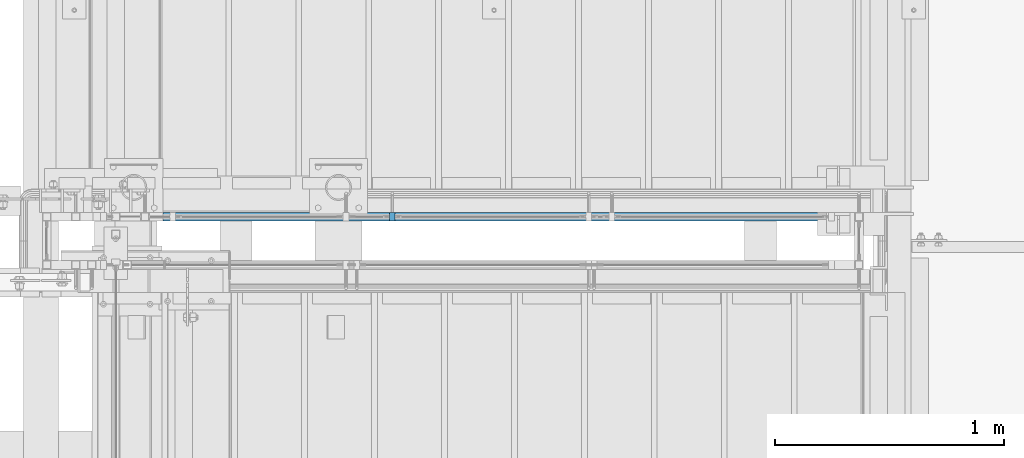
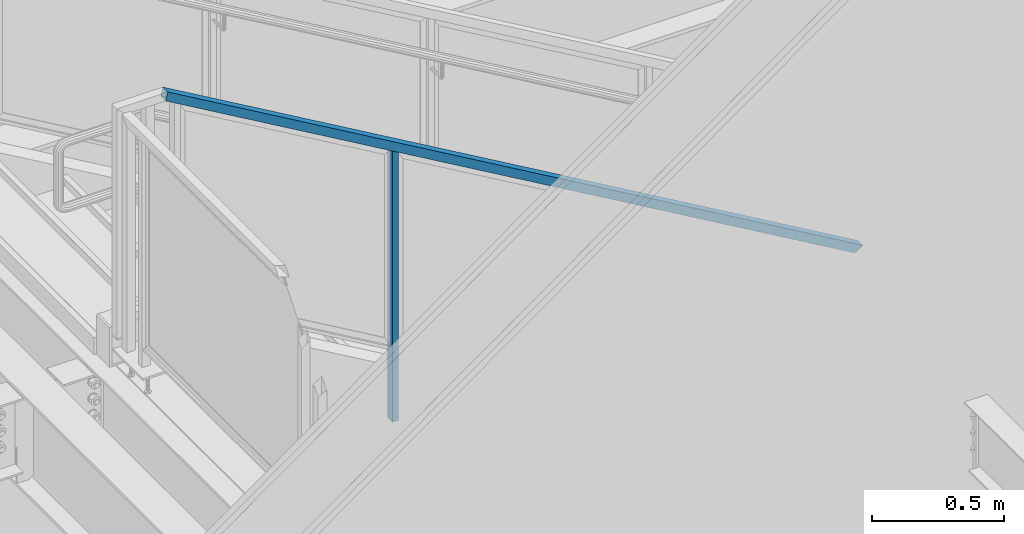
# One storey, part 794 of 1179: 2 members, 1 element without a shape of its own.
"""IFC2X3 building model written with IfcOpenShell, lengths in millimetres."""

from ifc_helpers import new_model, si_unit, frame, origin_with_axes, place, context, subcontext, project, spatial, faceted_brep, material, type_object, element, aggregate, save


model = new_model("IFC2X3")

# Units and contexts
model_context = context("Model", 3, precision=1e-05, world=origin_with_axes())
body_context = subcontext(model_context, "Body", "Model", "MODEL_VIEW")
ifc_project = project(units=[si_unit("LENGTHUNIT", "METRE", prefix="MILLI"), si_unit("AREAUNIT", "SQUARE_METRE"), si_unit("VOLUMEUNIT", "CUBIC_METRE"), si_unit("MASSUNIT", "GRAM", prefix="KILO"), si_unit("TIMEUNIT", "SECOND"), si_unit("PLANEANGLEUNIT", "RADIAN"), si_unit("SOLIDANGLEUNIT", "STERADIAN"), si_unit("THERMODYNAMICTEMPERATUREUNIT", "DEGREE_CELSIUS"), si_unit("LUMINOUSINTENSITYUNIT", "LUMEN")], contexts=[model_context])

# Site, building, storey
site_placement = place(None, origin_with_axes())
site = spatial("IfcSite", under=ifc_project, at=site_placement, CompositionType="ELEMENT")
building_placement = place(site_placement, origin_with_axes())
building = spatial("IfcBuilding", under=site, at=building_placement, Name="Undefined", CompositionType="ELEMENT")
storey_placement = place(building_placement, origin_with_axes())
storey = spatial("IfcBuildingStorey", under=building, at=storey_placement, Name="Undefined", CompositionType="ELEMENT", Elevation=0.0)

# Assembly, members
assembly_placement = place(storey_placement, origin_with_axes())
assembly = element("IfcElementAssembly", 1, at=assembly_placement, inside=storey, Name="GUARDRAIL", AssemblyPlace="NOTDEFINED", PredefinedType="RIGID_FRAME")
ifc_material_1 = material(Name="STEEL/A36")
member_type_1 = type_object("IfcMemberType", PredefinedType="NOTDEFINED")
member_1_placement = place(assembly_placement, frame((20810.0083338412, 39681.1500007796, 7355.33459241118), z_axis=(0.0, -1.0, 0.0), x_axis=(0.0, 0.0, 1.0)))
member_1 = element("IfcMember", 2, at=member_1_placement, type_object=member_type_1, material=ifc_material_1, Name="POST", context=body_context, shape_type="Brep", body=[
    faceted_brep([(0.0, 12.7000000000007, -19.0500000000029), (0.0, 12.7000000000007, 19.0500000000029), (1257.9937907086, 12.7000000000007, 19.0500000000029), (1257.9937907086, 12.7000000000007, -19.0500000000029), (0.0, -12.7000000000007, 19.0500000000029), (1243.17712405909, -12.7000000000007, 19.0500000000029), (0.0, -12.7000000000007, -19.0500000000029), (1243.17712405909, -12.7000000000007, -19.0500000000029)], [[[0, 1, 2, 3]], [[1, 4, 5, 2]], [[4, 6, 7, 5]], [[6, 0, 3, 7]], [[5, 7, 3, 2]], [[6, 4, 1, 0]]]),
])
ifc_material_2 = material()
member_type_2 = type_object("IfcMemberType", Name="HSS1-1/2X1-1/2X1/8", PredefinedType="NOTDEFINED")
member_2_placement = place(assembly_placement, frame((19805.65, 39681.150000777, 9213.8499999772), z_axis=(0.503871025088838, 0.0, 0.863778901152328), x_axis=(0.863778851027978, 0.0, -0.503871111016285)))
member_2 = element("IfcMember", 3, at=member_2_placement, type_object=member_type_2, material=ifc_material_2, Name="GUARDRAIL", ObjectType="HSS1-1/2X1-1/2X1/8", context=body_context, shape_type="Brep", body=[
    faceted_brep([(4.29179236063283, 15.874999282998, -15.8749992829871), (4.29179236063283, -15.874999282998, -15.8749992829871), (3508.53551728731, -15.874999282998, -15.874999282205), (3508.53551728731, 15.874999282998, -15.874999282205), (-4.29179248428773, -15.874999282998, 15.8749992829871), (3526.77177450846, -15.874999282998, 15.8749992837802), (-4.29179248428773, 15.874999282998, 15.8749992829871), (3526.77177450846, 15.874999282998, 15.8749992837802), (5.15015087091524, 19.0499992350015, -19.0499992349833), (-5.15015099456832, 19.0499992350015, 19.0499992349833), (3528.59540028537, 19.0499992350015, 19.04999923578), (3506.7118915104, 19.0499992350015, -19.0499992342011), (-5.15015099456832, -19.0499992350015, 19.0499992349833), (3528.59540028537, -19.0499992350015, 19.04999923578), (5.15015087091524, -19.0499992350015, -19.0499992349833), (3506.7118915104, -19.0499992350015, -19.0499992342011)], [[[0, 1, 2, 3]], [[1, 4, 5, 2]], [[4, 6, 7, 5]], [[6, 0, 3, 7]], [[8, 9, 10, 11]], [[9, 12, 13, 10]], [[12, 14, 15, 13]], [[14, 8, 11, 15]], [[13, 15, 11, 10], [5, 7, 3, 2]], [[14, 12, 9, 8], [6, 4, 1, 0]]]),
])
aggregate(assembly, [member_1, member_2])

save(model, "model.ifc")
